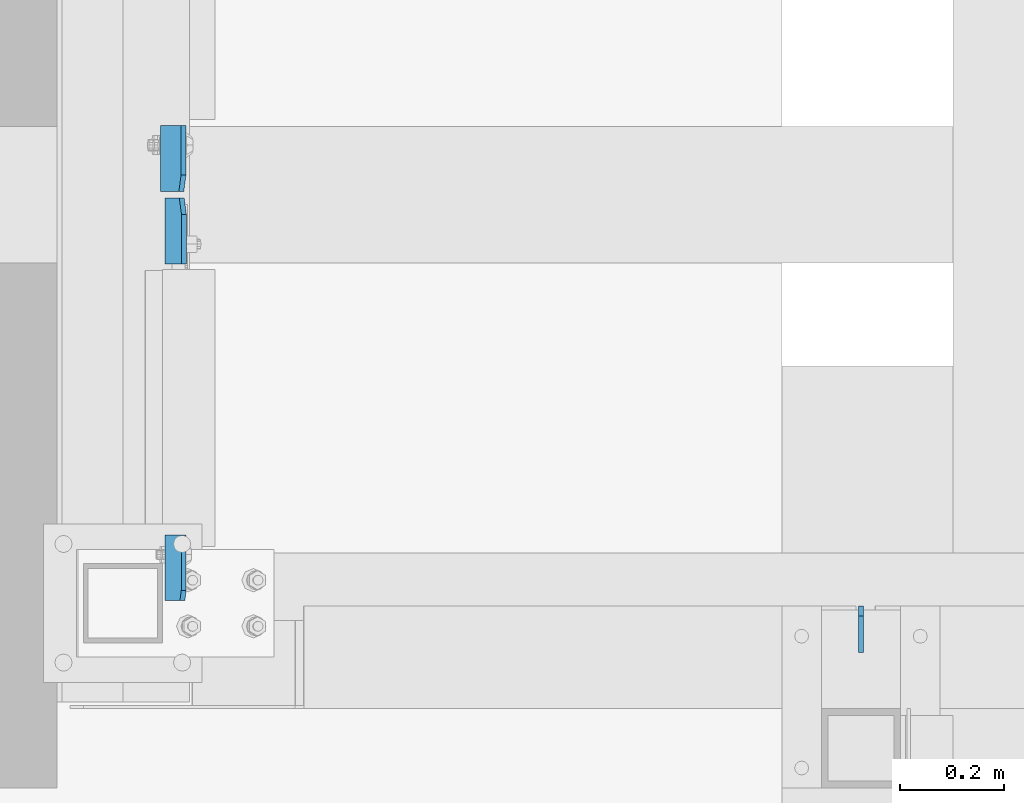
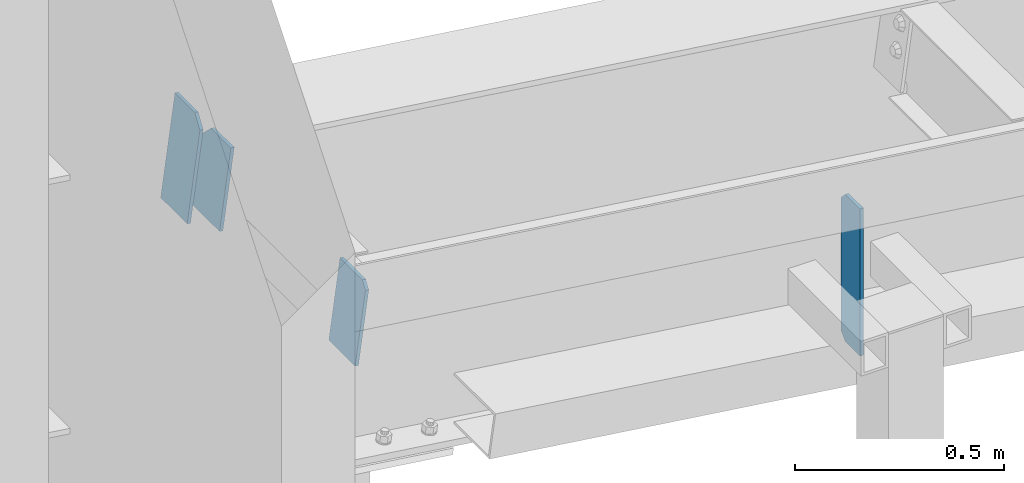
# One storey, part 1004 of 1179: 4 plates, 2 elements without a shape of their own.
"""IFC2X3 building model written with IfcOpenShell, lengths in millimetres."""

from ifc_helpers import new_model, si_unit, frame, origin_with_axes, place, context, subcontext, project, spatial, faceted_brep, material, type_object, element, aggregate, save


model = new_model("IFC2X3")

# Units and contexts
model_context = context("Model", 3, precision=1e-05, world=origin_with_axes())
body_context = subcontext(model_context, "Body", "Model", "MODEL_VIEW")
ifc_project = project(units=[si_unit("LENGTHUNIT", "METRE", prefix="MILLI"), si_unit("AREAUNIT", "SQUARE_METRE"), si_unit("VOLUMEUNIT", "CUBIC_METRE"), si_unit("MASSUNIT", "GRAM", prefix="KILO"), si_unit("TIMEUNIT", "SECOND"), si_unit("PLANEANGLEUNIT", "RADIAN"), si_unit("SOLIDANGLEUNIT", "STERADIAN"), si_unit("THERMODYNAMICTEMPERATUREUNIT", "DEGREE_CELSIUS"), si_unit("LUMINOUSINTENSITYUNIT", "LUMEN")], contexts=[model_context])

# Site, building, storey
site_placement = place(None, origin_with_axes())
site = spatial("IfcSite", under=ifc_project, at=site_placement, CompositionType="ELEMENT")
building_placement = place(site_placement, origin_with_axes())
building = spatial("IfcBuilding", under=site, at=building_placement, Name="Undefined", CompositionType="ELEMENT")
storey_placement = place(building_placement, origin_with_axes())
storey = spatial("IfcBuildingStorey", under=building, at=storey_placement, Name="Undefined", CompositionType="ELEMENT", Elevation=0.0)

# Assembly, plates
assembly_1_placement = place(storey_placement, origin_with_axes())
assembly_1 = element("IfcElementAssembly", 1, at=assembly_1_placement, inside=storey, Name="BEAM", AssemblyPlace="NOTDEFINED", PredefinedType="RIGID_FRAME")
ifc_material = material(Name="STEEL/A36")
plate_type_1 = type_object("IfcPlateType", PredefinedType="NOTDEFINED")
plate_1_placement = place(assembly_1_placement, frame((24983.6096004232, 5441.95, 7929.36411846658), z_axis=(0.0, 1.0, 0.0), x_axis=(-0.133813222971046, 0.0, -0.991006569785539)))
plate_1 = element("IfcPlate", 2, at=plate_1_placement, type_object=plate_type_1, material=ifc_material, Name="PLATE", context=body_context, shape_type="Brep", body=[
    faceted_brep([(1.81898940354586e-12, -4.76249999999709, 31.75), (0.0, -4.76249999999709, 127.0), (0.0, 4.76249999999709, 127.0), (-1.81898940354586e-12, 4.76249999998981, 31.75), (295.2750000003, -4.76249999965512, 127.0), (295.275000000298, 4.76250000034634, 127.0), (295.2750000003, -4.76249999965512, 0.0), (295.275000000298, 4.76250000034634, 0.0), (31.7499999988213, -4.76250000001164, 0.0), (31.7499999988249, 4.76249999998254, 0.0)], [[[0, 1, 2, 3]], [[1, 4, 5, 2]], [[4, 6, 7, 5]], [[6, 8, 9, 7]], [[8, 0, 3, 9]], [[5, 7, 9, 3, 2]], [[8, 6, 4, 1, 0]]]),
])
plate_2_placement = place(assembly_1_placement, frame((24984.396211888, 5429.25, 7929.25790422046), z_axis=(0.0, -1.0, 0.0), x_axis=(-0.133813222971046, 0.0, -0.991006569785539)))
plate_2 = element("IfcPlate", 3, at=plate_2_placement, type_object=plate_type_1, material=ifc_material, Name="PLATE", context=body_context, shape_type="Brep", body=[
    faceted_brep([(1.81898940354586e-12, -4.76249999999709, 31.75), (0.0, -4.76249999999709, 127.0), (0.0, 4.76249999999709, 127.0), (-1.81898940354586e-12, 4.76249999998981, 31.75), (234.950000000235, -4.76250000027358, 127.0), (234.950000000239, 4.76249999973516, 127.0), (234.950000000235, -4.76250000027358, 0.0), (234.950000000239, 4.76249999973516, 0.0), (31.7499999988213, -4.76250000001164, 0.0), (31.7499999988249, 4.76249999998254, 0.0)], [[[0, 1, 2, 3]], [[1, 4, 5, 2]], [[4, 6, 7, 5]], [[6, 8, 9, 7]], [[8, 0, 3, 9]], [[5, 7, 9, 3, 2]], [[8, 6, 4, 1, 0]]]),
])
aggregate(assembly_1, [plate_1, plate_2])

assembly_2_placement = place(storey_placement, origin_with_axes())
assembly_2 = element("IfcElementAssembly", 4, at=assembly_2_placement, inside=storey, Name="BEAM", AssemblyPlace="NOTDEFINED", PredefinedType="RIGID_FRAME")
plate_3_placement = place(assembly_2_placement, frame((24983.9713549017, 4653.75625, 7926.1114583618), z_axis=(0.0, 1.0, 0.0), x_axis=(-0.133813222971046, 0.0, -0.991006569785539)))
plate_3 = element("IfcPlate", 5, at=plate_3_placement, type_object=plate_type_1, material=ifc_material, Name="PLATE", context=body_context, shape_type="Brep", body=[
    faceted_brep([(0.0, -4.76250000000073, 19.0499992370605), (1.81898940354586e-12, -4.76249999999709, 126.20625), (-1.81898940354586e-12, 4.76249999999709, 126.20625), (0.0, 4.76250000000073, 19.0499992370605), (231.775000000234, -4.76249999972788, 126.20625), (231.775000000232, 4.76250000027358, 126.20625), (231.775000000234, -4.76249999972788, 0.0), (231.775000000232, 4.76250000027358, 0.0), (19.0499992370605, -4.76250000000073, 0.0), (19.0499992370605, 4.76250000000073, 0.0)], [[[0, 1, 2, 3]], [[1, 4, 5, 2]], [[4, 6, 7, 5]], [[6, 8, 9, 7]], [[8, 0, 3, 9]], [[5, 7, 9, 3, 2]], [[8, 6, 4, 1, 0]]]),
])
plate_type_2 = type_object("IfcPlateType", PredefinedType="NOTDEFINED")
plate_4_placement = place(assembly_2_placement, frame((26289.0, 4552.95, 7319.61236910065), z_axis=(0.0, 0.0, 1.0), x_axis=(0.0, 1.0, 0.0)))
plate_4 = element("IfcPlate", 6, at=plate_4_placement, type_object=plate_type_2, material=ifc_material, Name="PLATE", context=body_context, shape_type="Brep", body=[
    faceted_brep([(0.0, -4.76249999999709, 0.0), (0.0, -4.76250000000073, 429.641153904559), (0.0, 4.76250000000073, 429.641153904559), (0.0, 4.76249999999709, 0.0), (70.6437507629398, -4.76250000000073, 429.641153904559), (70.6437507629398, 4.76250000000073, 429.641153904559), (89.6937500000004, -4.76250000000073, 410.591154667499), (89.6937500000004, 4.76250000000073, 410.591154667499), (89.6937500000004, -4.76249999999709, 19.0499992370605), (89.6937500000004, 4.76249999999709, 19.0499992370605), (70.6437507629398, -4.76249999999709, 0.0), (70.6437507629398, 4.76249999999709, 0.0)], [[[0, 1, 2, 3]], [[1, 4, 5, 2]], [[4, 6, 7, 5]], [[6, 8, 9, 7]], [[8, 10, 11, 9]], [[10, 0, 3, 11]], [[5, 7, 9, 11, 3, 2]], [[10, 8, 6, 4, 1, 0]]]),
])
aggregate(assembly_2, [plate_3, plate_4])

save(model, "model.ifc")
